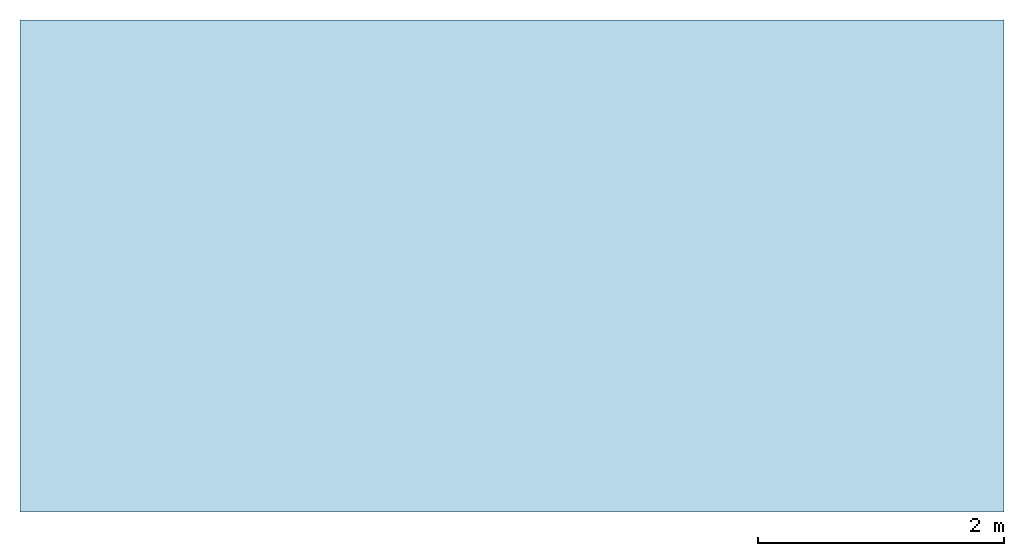
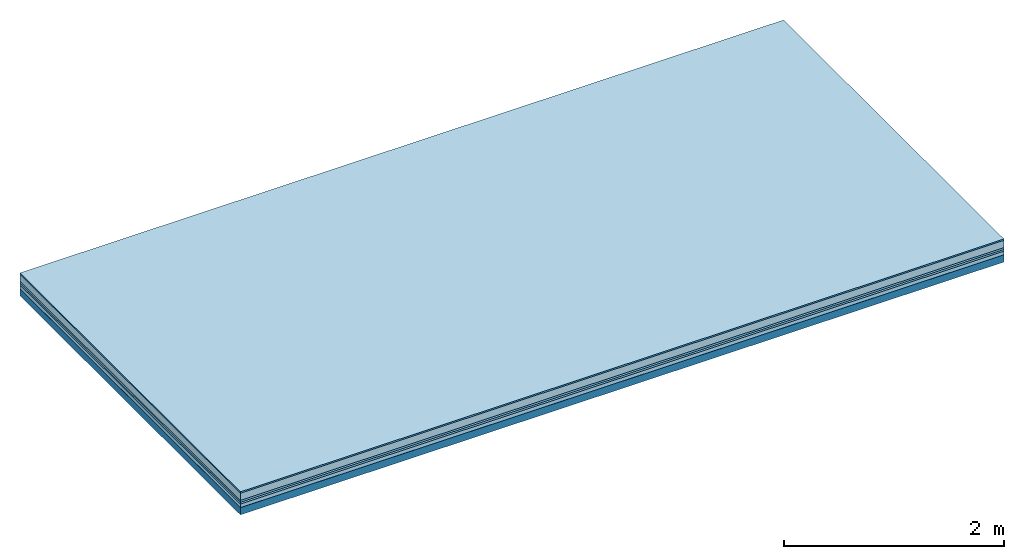
# One storey: 6 plates, 1 member, 1 element without a shape of its own.
"""IFC4 building model written with IfcOpenShell, lengths in metres."""

from ifc_helpers import new_model, si_unit, derived_unit, direction, frame, frame_2d, origin, origin_with_axes, place, context, project, spatial, rectangle, extrude, material, layer, layer_set, type_object, element, aggregate, save


model = new_model("IFC4")

# Units and contexts
plan_context = context("Plan", 3, precision=1e-05, world=origin(), true_north=direction((0.0, 1.0)))
model_context = context("Model", 3, precision=1e-05, world=origin(), true_north=direction((0.0, 1.0)))
ifc_project = project(units=[si_unit("LENGTHUNIT", "METRE"), derived_unit("SOUNDPRESSUREUNIT", [(si_unit("PRESSUREUNIT", "PASCAL", prefix="MICRO"), 0)]), si_unit("ENERGYUNIT", "JOULE", prefix="MEGA"), si_unit("MASSUNIT", "GRAM", prefix="KILO"), derived_unit("THERMALTRANSMITTANCEUNIT", [(si_unit("POWERUNIT", "WATT"), 1), (si_unit("AREAUNIT", "SQUARE_METRE"), -1), (si_unit("THERMODYNAMICTEMPERATUREUNIT", "KELVIN"), -1)]), derived_unit("AREADENSITYUNIT", [(si_unit("MASSUNIT", "GRAM", prefix="KILO"), 1), (si_unit("AREAUNIT", "SQUARE_METRE"), -1)]), derived_unit("USERDEFINED", [(si_unit("ENERGYUNIT", "JOULE", prefix="MEGA"), 1), (si_unit("AREAUNIT", "SQUARE_METRE"), -1)])], contexts=[plan_context, model_context])

# Site, building, storey
site = spatial("IfcSite", under=ifc_project)
building_placement = place(None, origin())
building = spatial("IfcBuilding", under=site, at=building_placement)
storey_placement = place(building_placement, origin())
storey = spatial("IfcBuildingStorey", under=building, at=storey_placement)

# Slab, member, plates
ifc_material_1 = material(Category="11.013")
ifc_layer_1 = layer(ifc_material_1, 0.015, Name="Flooring")
ifc_material_2 = material(Name="Cement screed", Category="04.006")
ifc_layer_2 = layer(ifc_material_2, 0.08, Name="On-material")
ifc_material_3 = material(Name="Wood fiber generic product", Category="10.009")
ifc_layer_3 = layer(ifc_material_3, 0.02, Name="Impact sound insulation")
ifc_material_4 = material()
ifc_layer_4 = layer(ifc_material_4, 0.02, Name="Additional insulation")
ifc_material_5 = material(Name="Cement panels, glued on sub-floor", Category="02.007")
ifc_layer_5 = layer(ifc_material_5, 0.04, Name="on Supporting structure")
ifc_material_6 = material(Name="protection", Category="09.007")
ifc_layer_6 = layer(ifc_material_6, 0.0005, Name="Sub-floor")
ifc_material_7 = material(Name="no composite action")
ifc_layer_7 = layer(ifc_material_7, 0.0, Name="Bond")
ifc_layer_8 = layer(None, 0.08, Name="Supporting structure")
ifc_layer_set = layer_set([ifc_layer_1, ifc_layer_2, ifc_layer_3, ifc_layer_4, ifc_layer_5, ifc_layer_6, ifc_layer_7, ifc_layer_8])
slab_type = type_object("IfcSlabType", Name="A2085", PredefinedType="NOTDEFINED", material=ifc_layer_set)
slab_placement = place(None, frame((0.0, 0.0, 0.0), z_axis=(0.0, 0.0, -1.0), x_axis=(1.0, 0.0, 0.0)))
slab = element("IfcSlab", 1, at=slab_placement, inside=storey, type_object=slab_type, material=ifc_layer_set, Name="Slab #1")
ifc_material_8 = material(Name="Solid timber panel")
member_placement = place(slab_placement, origin())
member = element("IfcMember", 2, at=member_placement, material=ifc_material_8, Name="Supporting structure", context=plan_context, shape_type="SweptSolid", body=[
    extrude(rectangle(XDim=1.0, YDim=0.08, at=frame_2d((0.5, 0.04), x_axis=(1.0, 0.0))), frame((0.0, 4.0, 0.1755), z_axis=(0.0, -1.0, 0.0), x_axis=(1.0, 0.0, 0.0)), (0.0, 0.0, 1.0), 4.0),
    extrude(rectangle(XDim=1.0, YDim=0.08, at=frame_2d((0.5, 0.04), x_axis=(1.0, 0.0))), frame((1.0, 4.0, 0.1755), z_axis=(0.0, -1.0, 0.0), x_axis=(1.0, 0.0, 0.0)), (0.0, 0.0, 1.0), 4.0),
    extrude(rectangle(XDim=1.0, YDim=0.08, at=frame_2d((0.5, 0.04), x_axis=(1.0, 0.0))), frame((2.0, 4.0, 0.1755), z_axis=(0.0, -1.0, 0.0), x_axis=(1.0, 0.0, 0.0)), (0.0, 0.0, 1.0), 4.0),
    extrude(rectangle(XDim=1.0, YDim=0.08, at=frame_2d((0.5, 0.04), x_axis=(1.0, 0.0))), frame((3.0, 4.0, 0.1755), z_axis=(0.0, -1.0, 0.0), x_axis=(1.0, 0.0, 0.0)), (0.0, 0.0, 1.0), 4.0),
    extrude(rectangle(XDim=1.0, YDim=0.08, at=frame_2d((0.5, 0.04), x_axis=(1.0, 0.0))), frame((4.0, 4.0, 0.1755), z_axis=(0.0, -1.0, 0.0), x_axis=(1.0, 0.0, 0.0)), (0.0, 0.0, 1.0), 4.0),
    extrude(rectangle(XDim=1.0, YDim=0.08, at=frame_2d((0.5, 0.04), x_axis=(1.0, 0.0))), frame((5.0, 4.0, 0.1755), z_axis=(0.0, -1.0, 0.0), x_axis=(1.0, 0.0, 0.0)), (0.0, 0.0, 1.0), 4.0),
    extrude(rectangle(XDim=1.0, YDim=0.08, at=frame_2d((0.5, 0.04), x_axis=(1.0, 0.0))), frame((6.0, 4.0, 0.1755), z_axis=(0.0, -1.0, 0.0), x_axis=(1.0, 0.0, 0.0)), (0.0, 0.0, 1.0), 4.0),
    extrude(rectangle(XDim=1.0, YDim=0.08, at=frame_2d((0.5, 0.04), x_axis=(1.0, 0.0))), frame((7.0, 4.0, 0.1755), z_axis=(0.0, -1.0, 0.0), x_axis=(1.0, 0.0, 0.0)), (0.0, 0.0, 1.0), 4.0),
])
plate_1_placement = place(slab_placement, origin())
plate_1 = element("IfcPlate", 3, at=plate_1_placement, material=ifc_material_1, Name="Flooring", context=plan_context, shape_type="SweptSolid", body=[
    extrude(rectangle(XDim=8.0, YDim=4.0, at=frame_2d((4.0, 2.0), x_axis=(1.0, 0.0))), origin_with_axes(), (0.0, 0.0, 1.0), 0.015),
])
plate_2_placement = place(slab_placement, origin())
plate_2 = element("IfcPlate", 4, at=plate_2_placement, material=ifc_material_2, Name="On-material", context=plan_context, shape_type="SweptSolid", body=[
    extrude(rectangle(XDim=8.0, YDim=4.0, at=frame_2d((4.0, 2.0), x_axis=(1.0, 0.0))), frame((0.0, 0.0, 0.015), z_axis=(0.0, 0.0, 1.0), x_axis=(1.0, 0.0, 0.0)), (0.0, 0.0, 1.0), 0.08),
])
plate_3_placement = place(slab_placement, origin())
plate_3 = element("IfcPlate", 5, at=plate_3_placement, material=ifc_material_3, Name="Impact sound insulation", context=plan_context, shape_type="SweptSolid", body=[
    extrude(rectangle(XDim=8.0, YDim=4.0, at=frame_2d((4.0, 2.0), x_axis=(1.0, 0.0))), frame((0.0, 0.0, 0.095), z_axis=(0.0, 0.0, 1.0), x_axis=(1.0, 0.0, 0.0)), (0.0, 0.0, 1.0), 0.02),
])
plate_4_placement = place(slab_placement, origin())
plate_4 = element("IfcPlate", 6, at=plate_4_placement, material=ifc_material_4, Name="Additional insulation", context=plan_context, shape_type="SweptSolid", body=[
    extrude(rectangle(XDim=8.0, YDim=4.0, at=frame_2d((4.0, 2.0), x_axis=(1.0, 0.0))), frame((0.0, 0.0, 0.115), z_axis=(0.0, 0.0, 1.0), x_axis=(1.0, 0.0, 0.0)), (0.0, 0.0, 1.0), 0.02),
])
plate_5_placement = place(slab_placement, origin())
plate_5 = element("IfcPlate", 7, at=plate_5_placement, material=ifc_material_5, Name="on Supporting structure", context=plan_context, shape_type="SweptSolid", body=[
    extrude(rectangle(XDim=8.0, YDim=4.0, at=frame_2d((4.0, 2.0), x_axis=(1.0, 0.0))), frame((0.0, 0.0, 0.135), z_axis=(0.0, 0.0, 1.0), x_axis=(1.0, 0.0, 0.0)), (0.0, 0.0, 1.0), 0.04),
])
plate_6_placement = place(slab_placement, origin())
plate_6 = element("IfcPlate", 8, at=plate_6_placement, material=ifc_material_6, Name="Sub-floor", context=plan_context, shape_type="SweptSolid", body=[
    extrude(rectangle(XDim=8.0, YDim=4.0, at=frame_2d((4.0, 2.0), x_axis=(1.0, 0.0))), frame((0.0, 0.0, 0.175), z_axis=(0.0, 0.0, 1.0), x_axis=(1.0, 0.0, 0.0)), (0.0, 0.0, 1.0), 0.0005),
])
aggregate(slab, [plate_1, plate_2, plate_3, plate_4, plate_5, plate_6, member])

save(model, "model.ifc")
